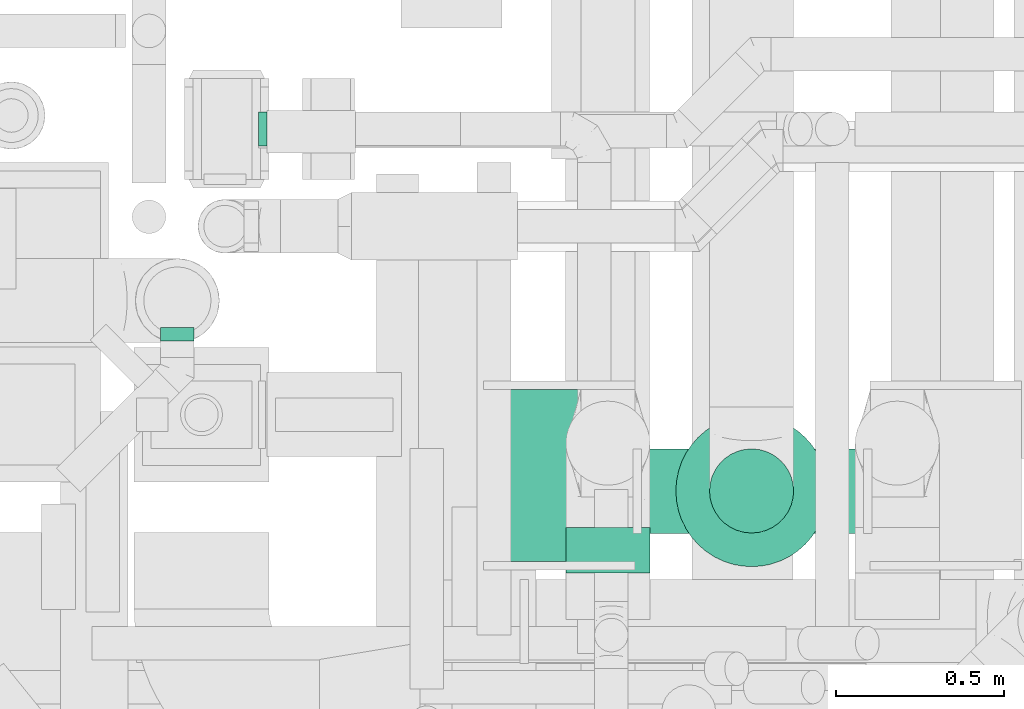
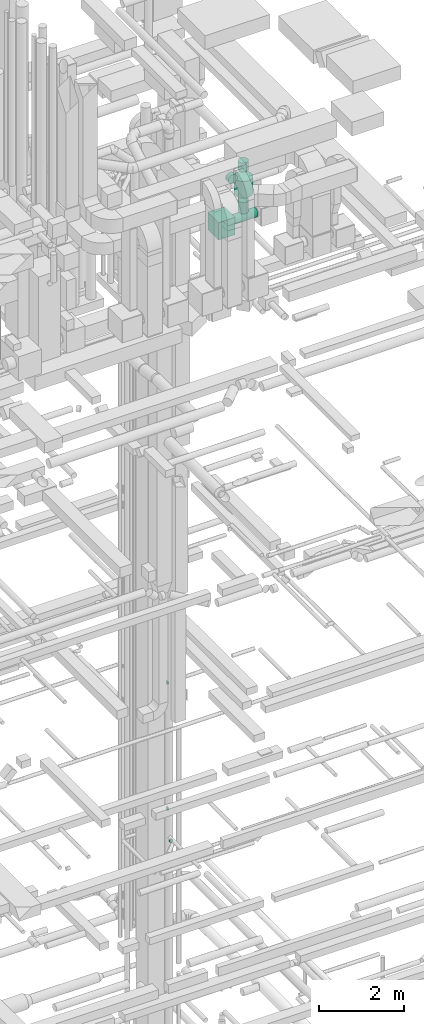
# One storey, part 239 of 337: 6 flow segments, 3 flow fittings.
"""IFC2X3 building model written with IfcOpenShell, lengths in millimetres."""

from ifc_helpers import new_model, entity, si_unit, converted_unit, derived_unit, direction, frame, origin, origin_2d_with_axis, place, context, subcontext, project, spatial, rectangle, circle, extrude, faceted_brep, source, transform, mapped, material, type_object, type_shapes, element, save


model = new_model("IFC2X3")

# Units and contexts
model_context = context("Model", 3, precision=0.01, world=origin(), true_north=direction((6.12303176911189e-17, 1.0)))
body_context = subcontext(model_context, "Body", "Model", "MODEL_VIEW")
ifc_project = project(units=[si_unit("LENGTHUNIT", "METRE", prefix="MILLI"), si_unit("AREAUNIT", "SQUARE_METRE"), si_unit("VOLUMEUNIT", "CUBIC_METRE"), converted_unit("PLANEANGLEUNIT", "DEGREE", entity("IfcRatioMeasure", 0.0174532925199433), si_unit("PLANEANGLEUNIT", "RADIAN"), dimensions=[0, 0, 0, 0, 0, 0, 0]), si_unit("MASSUNIT", "GRAM", prefix="KILO"), derived_unit("MASSDENSITYUNIT", [(si_unit("MASSUNIT", "GRAM", prefix="KILO"), 1), (si_unit("LENGTHUNIT", "METRE"), -3)]), derived_unit("MOMENTOFINERTIAUNIT", [(si_unit("LENGTHUNIT", "METRE"), 4)]), si_unit("TIMEUNIT", "SECOND"), si_unit("FREQUENCYUNIT", "HERTZ"), si_unit("THERMODYNAMICTEMPERATUREUNIT", "DEGREE_CELSIUS"), derived_unit("THERMALTRANSMITTANCEUNIT", [(si_unit("MASSUNIT", "GRAM", prefix="KILO"), 1), (si_unit("THERMODYNAMICTEMPERATUREUNIT", "KELVIN"), -1), (si_unit("TIMEUNIT", "SECOND"), -3)]), derived_unit("VOLUMETRICFLOWRATEUNIT", [(si_unit("LENGTHUNIT", "METRE"), 3), (si_unit("TIMEUNIT", "SECOND"), -1)]), derived_unit("MASSFLOWRATEUNIT", [(si_unit("MASSUNIT", "GRAM", prefix="KILO"), 1), (si_unit("TIMEUNIT", "SECOND"), -1)]), derived_unit("ROTATIONALFREQUENCYUNIT", [(si_unit("TIMEUNIT", "SECOND"), -1)]), si_unit("ELECTRICCURRENTUNIT", "AMPERE"), si_unit("ELECTRICVOLTAGEUNIT", "VOLT"), si_unit("POWERUNIT", "WATT"), si_unit("FORCEUNIT", "NEWTON", prefix="KILO"), si_unit("ILLUMINANCEUNIT", "LUX"), si_unit("LUMINOUSFLUXUNIT", "LUMEN"), si_unit("LUMINOUSINTENSITYUNIT", "CANDELA"), derived_unit("USERDEFINED", [(si_unit("MASSUNIT", "GRAM", prefix="KILO"), -1), (si_unit("LENGTHUNIT", "METRE"), -2), (si_unit("TIMEUNIT", "SECOND"), 3), (si_unit("LUMINOUSFLUXUNIT", "LUMEN"), 1)]), derived_unit("LINEARVELOCITYUNIT", [(si_unit("LENGTHUNIT", "METRE"), 1), (si_unit("TIMEUNIT", "SECOND"), -1)]), si_unit("PRESSUREUNIT", "PASCAL"), derived_unit("USERDEFINED", [(si_unit("LENGTHUNIT", "METRE"), -2), (si_unit("MASSUNIT", "GRAM", prefix="KILO"), 1), (si_unit("TIMEUNIT", "SECOND"), -2)]), derived_unit("LINEARFORCEUNIT", [(si_unit("MASSUNIT", "GRAM", prefix="KILO"), 1), (si_unit("LENGTHUNIT", "METRE"), 1), (si_unit("TIMEUNIT", "SECOND"), -2), (si_unit("LENGTHUNIT", "METRE"), -1)]), derived_unit("PLANARFORCEUNIT", [(si_unit("MASSUNIT", "GRAM", prefix="KILO"), 1), (si_unit("LENGTHUNIT", "METRE"), 1), (si_unit("TIMEUNIT", "SECOND"), -2), (si_unit("LENGTHUNIT", "METRE"), -2)])], contexts=[model_context])

# Site, building, storey
site_placement = place(None, origin())
site = spatial("IfcSite", under=ifc_project, at=site_placement, CompositionType="ELEMENT")
building_placement = place(site_placement, origin())
building = spatial("IfcBuilding", under=site, at=building_placement, CompositionType="ELEMENT")
storey_placement = place(building_placement, origin())
storey = spatial("IfcBuildingStorey", under=building, at=storey_placement, CompositionType="ELEMENT", Elevation=0.0)

# Flow segments
duct_segment_type_1 = type_object("IfcDuctSegmentType", PredefinedType="NOTDEFINED")
flow_segment_1_placement = place(storey_placement, frame((60318.66, 10528.49, 28450.0)))
element("IfcFlowSegment", 1, at=flow_segment_1_placement, inside=storey, type_object=duct_segment_type_1, context=body_context, shape_type="SweptSolid", body=[
    extrude(rectangle(XDim=512.000000000001, YDim=450.000000000002, at=origin_2d_with_axis()), frame((225.0, 256.0, 0.0), z_axis=(0.0, 0.0, 1.0), x_axis=(0.0, 1.0, 0.0)), (0.0, 0.0, 1.0), 499.999999999999),
])
duct_segment_type_2 = type_object("IfcDuctSegmentType", PredefinedType="NOTDEFINED")
flow_segment_2_placement = place(storey_placement, frame((60788.66, 10610.89, 28613.4)))
element("IfcFlowSegment", 2, at=flow_segment_2_placement, inside=storey, type_object=duct_segment_type_2, context=body_context, shape_type="SweptSolid", body=[
    extrude(circle(Radius=125.0, at=origin_2d_with_axis()), frame((0.0, 126.6, 126.6), z_axis=(1.0, 0.0, 0.0), x_axis=(0.0, 1.0, 0.0)), (0.0, 0.0, 1.0), 658.999999999963),
])
flow_segment_3_placement = place(storey_placement, frame((60561.56, 10495.19, 29973.4)))
element("IfcFlowSegment", 3, at=flow_segment_3_placement, inside=storey, type_object=duct_segment_type_2, context=body_context, shape_type="SweptSolid", body=[
    extrude(circle(Radius=125.0, at=origin_2d_with_axis()), frame((126.6, 0.0, 126.6), z_axis=(0.0, 1.0, 0.0), x_axis=(-1.0, 0.0, 0.0)), (0.0, 0.0, 1.0), 135.302523354539),
])
flow_segment_4_placement = place(storey_placement, frame((60988.7, 10611.88, 28885.0)))
element("IfcFlowSegment", 4, at=flow_segment_4_placement, inside=storey, type_object=duct_segment_type_2, context=body_context, shape_type="SweptSolid", body=[
    extrude(circle(Radius=125.0, at=origin_2d_with_axis()), frame((126.6, 126.6, 0.0), z_axis=(0.0, 0.0, 1.0), x_axis=(0.0, -1.0, 0.0)), (0.0, 0.0, 1.0), 325.003921371857),
])
flow_segment_5_placement = place(storey_placement, frame((60888.7, 10511.88, 29410.0)))
element("IfcFlowSegment", 5, at=flow_segment_5_placement, inside=storey, type_object=duct_segment_type_2, context=body_context, shape_type="SweptSolid", body=[
    extrude(circle(Radius=225.0, at=origin_2d_with_axis()), frame((226.6, 226.6, 0.0), z_axis=(0.0, 0.0, 1.0), x_axis=(0.0, -1.0, 0.0)), (0.0, 0.0, 1.0), 481.212144458727),
])
flow_segment_6_placement = place(storey_placement, frame((60988.7, 10611.88, 30091.2)))
element("IfcFlowSegment", 6, at=flow_segment_6_placement, inside=storey, type_object=duct_segment_type_2, context=body_context, shape_type="SweptSolid", body=[
    extrude(circle(Radius=125.0, at=origin_2d_with_axis()), frame((126.6, 126.6, 0.01), z_axis=(0.0, 5.9006736479374e-05, 1.0), x_axis=(0.0, -1.0, 5.9006736479374e-05)), (0.0, 0.0, 1.0), 258.787859398848),
])

# Flow fittings
ifc_material = material()
duct_fitting_type_1 = type_object("IfcDuctFittingType", PredefinedType="NOTDEFINED", material=ifc_material)
shared_shape_1 = source(origin(), body_context, "Body", "Brep", [
    faceted_brep([(20.0, 12.94, -48.3), (20.0, 25.0, -43.3), (20.0, 35.36, -35.36), (20.0, 43.3, -25.0), (20.0, 48.3, -12.94), (20.0, 50.0, 0.0), (20.0, 48.3, 12.94), (20.0, 43.3, 25.0), (20.0, 35.36, 35.36), (20.0, 25.0, 43.3), (20.0, 12.94, 48.3), (20.0, 0.0, 50.0), (20.0, -12.94, 48.3), (20.0, -25.0, 43.3), (20.0, -35.36, 35.36), (20.0, -43.3, 25.0), (20.0, -48.3, 12.94), (20.0, -50.0, 0.0), (20.0, -48.3, -12.94), (20.0, -43.3, -25.0), (20.0, -35.36, -35.36), (20.0, -25.0, -43.3), (20.0, -12.94, -48.3), (20.0, 0.0, -50.0), (0.0, 0.0, 50.0), (0.0, 12.94, 48.3), (-6.1, 12.94, 48.3), (-6.1, 0.0, 50.0), (0.0, 25.0, 43.3), (-6.1, 25.0, 43.3), (0.0, 35.36, 35.36), (-6.1, 35.36, 35.36), (0.0, 43.3, 25.0), (0.0, 48.3, 12.94), (-6.1, 48.3, 12.94), (-6.1, 43.3, 25.0), (0.0, 50.0, 0.0), (-6.1, 50.0, 0.0), (0.0, 48.3, -12.94), (-6.1, 48.3, -12.94), (0.0, 43.3, -25.0), (-6.1, 43.3, -25.0), (0.0, 35.36, -35.36), (-6.1, 35.36, -35.36), (0.0, 25.0, -43.3), (0.0, 12.94, -48.3), (-6.1, 12.94, -48.3), (-6.1, 25.0, -43.3), (0.0, 0.0, -50.0), (-6.1, 0.0, -50.0), (0.0, -12.94, -48.3), (-6.1, -12.94, -48.3), (0.0, -25.0, -43.3), (-6.1, -25.0, -43.3), (0.0, -35.36, -35.36), (-6.1, -35.36, -35.36), (0.0, -43.3, -25.0), (0.0, -48.3, -12.94), (-6.1, -48.3, -12.94), (-6.1, -43.3, -25.0), (0.0, -50.0, 0.0), (-6.1, -50.0, 0.0), (0.0, -48.3, 12.94), (-6.1, -48.3, 12.94), (0.0, -43.3, 25.0), (-6.1, -43.3, 25.0), (0.0, -35.36, 35.36), (-6.1, -35.36, 35.36), (0.0, -25.0, 43.3), (0.0, -12.94, 48.3), (-6.1, -12.94, 48.3), (-6.1, -25.0, 43.3)], [[[0, 1, 2, 3, 4, 5, 6, 7, 8, 9, 10, 11, 12, 13, 14, 15, 16, 17, 18, 19, 20, 21, 22, 23]], [[24, 11, 10, 25, 26, 27]], [[25, 10, 9, 28, 29, 26]], [[28, 9, 8, 30, 31, 29]], [[32, 7, 6, 33, 34, 35]], [[33, 6, 5, 36, 37, 34]], [[30, 8, 7, 32, 35, 31]], [[36, 5, 4, 38, 39, 37]], [[38, 4, 3, 40, 41, 39]], [[40, 3, 2, 42, 43, 41]], [[44, 1, 0, 45, 46, 47]], [[45, 0, 23, 48, 49, 46]], [[42, 2, 1, 44, 47, 43]], [[48, 23, 22, 50, 51, 49]], [[50, 22, 21, 52, 53, 51]], [[52, 21, 20, 54, 55, 53]], [[56, 19, 18, 57, 58, 59]], [[57, 18, 17, 60, 61, 58]], [[54, 20, 19, 56, 59, 55]], [[60, 17, 16, 62, 63, 61]], [[62, 16, 15, 64, 65, 63]], [[64, 15, 14, 66, 67, 65]], [[68, 13, 12, 69, 70, 71]], [[69, 12, 11, 24, 27, 70]], [[66, 14, 13, 68, 71, 67]], [[49, 51, 53, 55, 59, 58, 61, 63, 65, 67, 71, 70, 27, 26, 29, 31, 35, 34, 37, 39, 41, 43, 47, 46]]]),
])
type_shapes(duct_fitting_type_1, [shared_shape_1])
for number, where, z_axis, x_axis in (
    (7, (59655.69, 11814.2, 11520.0), (0.0, -1.0, 0.0), (1.0, 0.0, 0.0)),
    (8, (59655.69, 11814.2, 15150.0), (0.0, -1.0, 0.0), (1.0, 0.0, 0.0)),
):
    element("IfcFlowFitting", number, at=place(storey_placement, frame(where, z_axis=z_axis, x_axis=x_axis)), inside=storey, type_object=duct_fitting_type_1, material=ifc_material, context=body_context, shape_type="MappedRepresentation", body=[
        mapped(shared_shape_1, transform((0.0, 0.0, 0.0), scale=1.0)),
    ])
duct_fitting_type_2 = type_object("IfcDuctFittingType", PredefinedType="NOTDEFINED", material=ifc_material)
shared_shape_2 = source(origin(), body_context, "Body", "Brep", [
    faceted_brep([(20.0, 12.94, -48.3), (20.0, 25.0, -43.3), (20.0, 35.36, -35.36), (20.0, 43.3, -25.0), (20.0, 48.3, -12.94), (20.0, 50.0, 0.0), (20.0, 48.3, 12.94), (20.0, 43.3, 25.0), (20.0, 35.36, 35.36), (20.0, 25.0, 43.3), (20.0, 12.94, 48.3), (20.0, 0.0, 50.0), (20.0, -12.94, 48.3), (20.0, -25.0, 43.3), (20.0, -35.36, 35.36), (20.0, -43.3, 25.0), (20.0, -48.3, 12.94), (20.0, -50.0, 0.0), (20.0, -48.3, -12.94), (20.0, -43.3, -25.0), (20.0, -35.36, -35.36), (20.0, -25.0, -43.3), (20.0, -12.94, -48.3), (20.0, 0.0, -50.0), (0.0, 0.0, 50.0), (0.0, 12.94, 48.3), (-19.49, 12.94, 48.3), (-19.49, 0.0, 50.0), (0.0, 25.0, 43.3), (-19.49, 25.0, 43.3), (0.0, 35.36, 35.36), (-19.49, 35.36, 35.36), (0.0, 43.3, 25.0), (0.0, 48.3, 12.94), (-19.49, 48.3, 12.94), (-19.49, 43.3, 25.0), (0.0, 50.0, 0.0), (-19.49, 50.0, 0.0), (0.0, 48.3, -12.94), (-19.49, 48.3, -12.94), (0.0, 43.3, -25.0), (-19.49, 43.3, -25.0), (0.0, 35.36, -35.36), (-19.49, 35.36, -35.36), (0.0, 25.0, -43.3), (0.0, 12.94, -48.3), (-19.49, 12.94, -48.3), (-19.49, 25.0, -43.3), (0.0, 0.0, -50.0), (-19.49, 0.0, -50.0), (0.0, -12.94, -48.3), (-19.49, -12.94, -48.3), (0.0, -25.0, -43.3), (-19.49, -25.0, -43.3), (0.0, -35.36, -35.36), (-19.49, -35.36, -35.36), (0.0, -43.3, -25.0), (0.0, -48.3, -12.94), (-19.49, -48.3, -12.94), (-19.49, -43.3, -25.0), (0.0, -50.0, 0.0), (-19.49, -50.0, 0.0), (0.0, -48.3, 12.94), (-19.49, -48.3, 12.94), (0.0, -43.3, 25.0), (-19.49, -43.3, 25.0), (0.0, -35.36, 35.36), (-19.49, -35.36, 35.36), (0.0, -25.0, 43.3), (0.0, -12.94, 48.3), (-19.49, -12.94, 48.3), (-19.49, -25.0, 43.3)], [[[0, 1, 2, 3, 4, 5, 6, 7, 8, 9, 10, 11, 12, 13, 14, 15, 16, 17, 18, 19, 20, 21, 22, 23]], [[24, 11, 10, 25, 26, 27]], [[25, 10, 9, 28, 29, 26]], [[28, 9, 8, 30, 31, 29]], [[32, 7, 6, 33, 34, 35]], [[33, 6, 5, 36, 37, 34]], [[30, 8, 7, 32, 35, 31]], [[36, 5, 4, 38, 39, 37]], [[38, 4, 3, 40, 41, 39]], [[40, 3, 2, 42, 43, 41]], [[44, 1, 0, 45, 46, 47]], [[45, 0, 23, 48, 49, 46]], [[42, 2, 1, 44, 47, 43]], [[48, 23, 22, 50, 51, 49]], [[50, 22, 21, 52, 53, 51]], [[52, 21, 20, 54, 55, 53]], [[56, 19, 18, 57, 58, 59]], [[57, 18, 17, 60, 61, 58]], [[54, 20, 19, 56, 59, 55]], [[60, 17, 16, 62, 63, 61]], [[62, 16, 15, 64, 65, 63]], [[64, 15, 14, 66, 67, 65]], [[68, 13, 12, 69, 70, 71]], [[69, 12, 11, 24, 27, 70]], [[66, 14, 13, 68, 71, 67]], [[49, 51, 53, 55, 59, 58, 61, 63, 65, 67, 71, 70, 27, 26, 29, 31, 35, 34, 37, 39, 41, 43, 47, 46]]]),
])
type_shapes(duct_fitting_type_2, [shared_shape_2])
flow_fitting_placement = place(storey_placement, frame((59408.94, 11204.18, 11050.0), z_axis=(-1.0, 0.0, 0.0), x_axis=(0.0, -1.0, 0.0)))
element("IfcFlowFitting", 9, at=flow_fitting_placement, inside=storey, type_object=duct_fitting_type_2, material=ifc_material, context=body_context, shape_type="MappedRepresentation", body=[
    mapped(shared_shape_2, transform((0.0, 0.0, 0.0), scale=1.0)),
])

save(model, "model.ifc")
